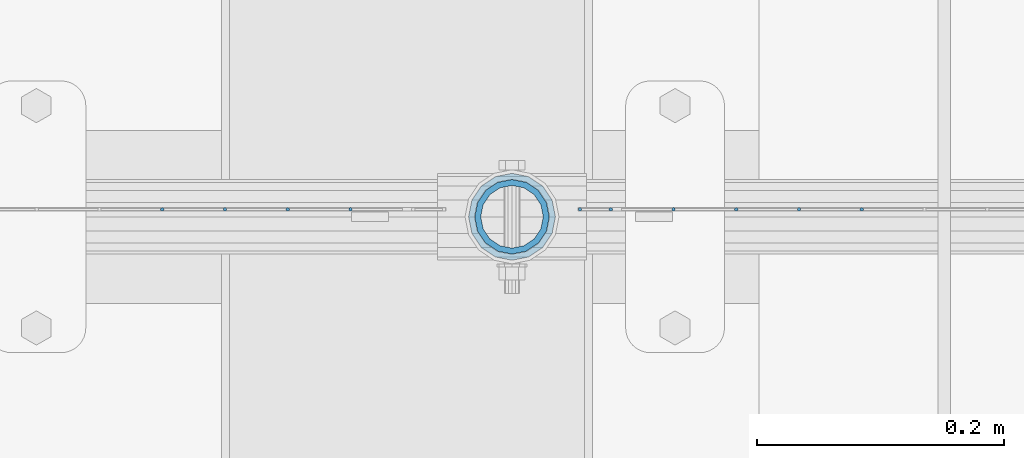
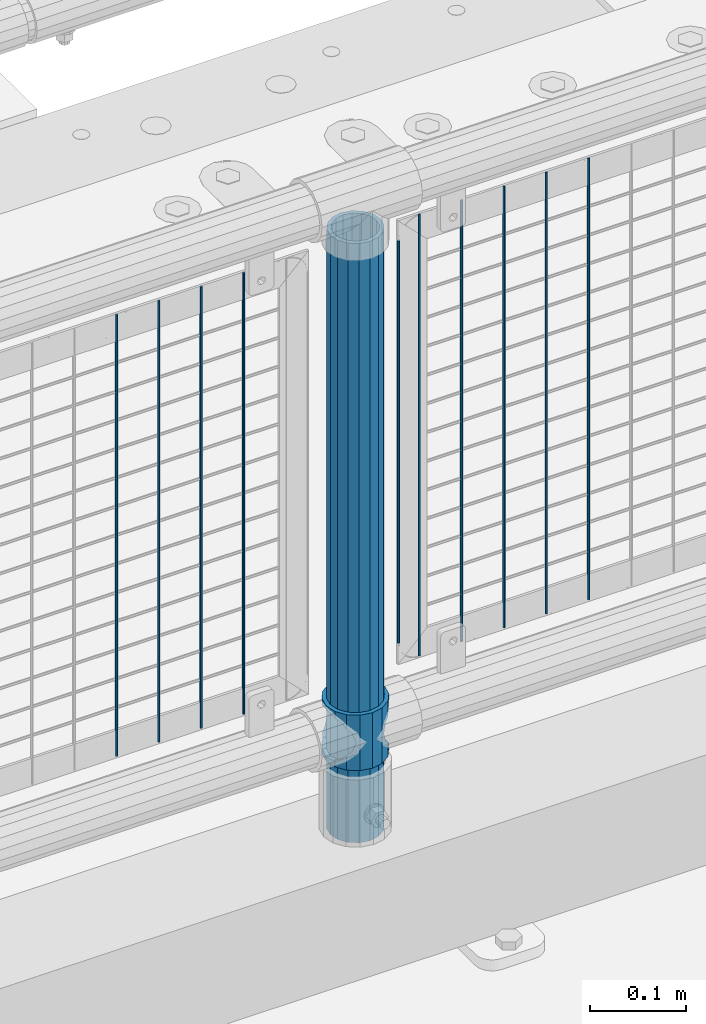
# One storey, part 91 of 242: 12 columns.
"""IFC2X3 building model written with IfcOpenShell, lengths in millimetres."""

from ifc_helpers import new_model, si_unit, frame, origin_with_axes, place, context, subcontext, project, spatial, faceted_brep, material, type_object, element, save


model = new_model("IFC2X3")

# Units and contexts
model_context = context("Model", 3, precision=1e-05, world=origin_with_axes())
body_context = subcontext(model_context, "Body", "Model", "MODEL_VIEW")
ifc_project = project(units=[si_unit("LENGTHUNIT", "METRE", prefix="MILLI"), si_unit("AREAUNIT", "SQUARE_METRE"), si_unit("VOLUMEUNIT", "CUBIC_METRE"), si_unit("MASSUNIT", "GRAM", prefix="KILO"), si_unit("TIMEUNIT", "SECOND"), si_unit("PLANEANGLEUNIT", "RADIAN"), si_unit("SOLIDANGLEUNIT", "STERADIAN"), si_unit("THERMODYNAMICTEMPERATUREUNIT", "DEGREE_CELSIUS"), si_unit("LUMINOUSINTENSITYUNIT", "LUMEN")], contexts=[model_context])

# Site, building, storey
site_placement = place(None, origin_with_axes())
site = spatial("IfcSite", under=ifc_project, at=site_placement, CompositionType="ELEMENT")
building_placement = place(site_placement, origin_with_axes())
building = spatial("IfcBuilding", under=site, at=building_placement, Name="Standard", CompositionType="ELEMENT")
storey_placement = place(building_placement, origin_with_axes())
storey = spatial("IfcBuildingStorey", under=building, at=storey_placement, Name="Undefined", CompositionType="ELEMENT", Elevation=0.0)

# Columns
ifc_material_1 = material()
column_type_1 = type_object("IfcColumnType", PredefinedType="NOTDEFINED")
column_1_placement = place(storey_placement, frame((-28765.0, -19335.5, 168.02), z_axis=(-1.0, 0.0, 0.0), x_axis=(0.0, 0.0, 1.0)))
element("IfcColumn", 1, at=column_1_placement, inside=storey, type_object=column_type_1, material=ifc_material_1, context=body_context, shape_type="Brep", body=[
    faceted_brep([(0.0, -25.3499999999985, 0.0), (0.0, -23.4203461491597, 9.70102501045403), (760.0, -23.4203461491597, 9.70102501045403), (760.0, -25.3499999999985, 0.0), (0.0, -17.9251569030785, 17.9251569030785), (760.0, -17.9251569030785, 17.9251569030785), (0.0, -9.70102501045403, 23.4203461491597), (760.0, -9.70102501045403, 23.4203461491597), (0.0, 0.0, 25.3499999999985), (760.0, 0.0, 25.3499999999985), (0.0, 9.70102501045403, 23.4203461491597), (760.0, 9.70102501045403, 23.4203461491597), (0.0, 17.9251569030785, 17.9251569030785), (760.0, 17.9251569030785, 17.9251569030785), (0.0, 23.4203461491597, 9.70102501045403), (760.0, 23.4203461491597, 9.70102501045403), (0.0, 25.3499999999985, 0.0), (760.0, 25.3499999999985, 0.0), (0.0, 23.4203461491597, -9.70102501045403), (760.0, 23.4203461491597, -9.70102501045403), (0.0, 17.9251569030785, -17.9251569030785), (760.0, 17.9251569030785, -17.9251569030785), (0.0, 9.70102501045403, -23.4203461491597), (760.0, 9.70102501045403, -23.4203461491597), (0.0, 0.0, -25.3499999999985), (760.0, 0.0, -25.3499999999985), (0.0, -9.70102501045403, -23.4203461491597), (760.0, -9.70102501045403, -23.4203461491597), (0.0, -17.9251569030785, -17.9251569030785), (760.0, -17.9251569030785, -17.9251569030785), (0.0, -23.4203461491597, -9.70102501045403), (760.0, -23.4203461491597, -9.70102501045403), (0.0, -30.1500000000015, 0.0), (0.0, -27.8549679052157, -11.5379054858058), (760.0, -27.8549679052157, -11.5379054858058), (760.0, -30.1500000000015, 0.0), (0.0, -21.3192694527752, -21.3192694527752), (760.0, -21.3192694527752, -21.3192694527752), (0.0, -11.5379054858058, -27.8549679052157), (760.0, -11.5379054858058, -27.8549679052157), (0.0, 0.0, -30.1500000000015), (760.0, 0.0, -30.1500000000015), (0.0, 11.5379054858058, -27.8549679052157), (760.0, 11.5379054858058, -27.8549679052157), (0.0, 21.3192694527752, -21.3192694527752), (760.0, 21.3192694527752, -21.3192694527752), (0.0, 27.8549679052157, -11.5379054858058), (760.0, 27.8549679052157, -11.5379054858058), (0.0, 30.1500000000015, 0.0), (760.0, 30.1500000000015, 0.0), (0.0, 27.8549679052157, 11.5379054858058), (760.0, 27.8549679052157, 11.5379054858058), (0.0, 21.3192694527752, 21.3192694527752), (760.0, 21.3192694527752, 21.3192694527752), (0.0, 11.5379054858058, 27.8549679052157), (760.0, 11.5379054858058, 27.8549679052157), (0.0, 0.0, 30.1500000000015), (760.0, 0.0, 30.1500000000015), (0.0, -11.5379054858058, 27.8549679052157), (760.0, -11.5379054858058, 27.8549679052157), (0.0, -21.3192694527752, 21.3192694527752), (760.0, -21.3192694527752, 21.3192694527752), (0.0, -27.8549679052157, 11.5379054858058), (760.0, -27.8549679052157, 11.5379054858058)], [[[0, 1, 2, 3]], [[1, 4, 5, 2]], [[4, 6, 7, 5]], [[6, 8, 9, 7]], [[8, 10, 11, 9]], [[10, 12, 13, 11]], [[12, 14, 15, 13]], [[14, 16, 17, 15]], [[16, 18, 19, 17]], [[18, 20, 21, 19]], [[20, 22, 23, 21]], [[22, 24, 25, 23]], [[24, 26, 27, 25]], [[26, 28, 29, 27]], [[28, 30, 31, 29]], [[30, 0, 3, 31]], [[32, 33, 34, 35]], [[33, 36, 37, 34]], [[36, 38, 39, 37]], [[38, 40, 41, 39]], [[40, 42, 43, 41]], [[42, 44, 45, 43]], [[44, 46, 47, 45]], [[46, 48, 49, 47]], [[48, 50, 51, 49]], [[50, 52, 53, 51]], [[52, 54, 55, 53]], [[54, 56, 57, 55]], [[56, 58, 59, 57]], [[58, 60, 61, 59]], [[60, 62, 63, 61]], [[62, 32, 35, 63]], [[37, 39, 41, 43, 45, 47, 49, 51, 53, 55, 57, 59, 61, 63, 35, 34], [5, 7, 9, 11, 13, 15, 17, 19, 21, 23, 25, 27, 29, 31, 3, 2]], [[62, 60, 58, 56, 54, 52, 50, 48, 46, 44, 42, 40, 38, 36, 33, 32], [30, 28, 26, 24, 22, 20, 18, 16, 14, 12, 10, 8, 6, 4, 1, 0]]]),
])
ifc_material_2 = material(Name="Misc_Undefined")
column_type_2 = type_object("IfcColumnType", PredefinedType="NOTDEFINED")
column_2_placement = place(storey_placement, frame((-28765.0, -19335.5, 263.02), z_axis=(-1.0, 0.0, 0.0), x_axis=(0.0, 0.0, 1.0)))
element("IfcColumn", 2, at=column_2_placement, inside=storey, type_object=column_type_2, material=ifc_material_2, context=body_context, shape_type="Brep", body=[
    faceted_brep([(63.1897438117172, 11.614442172282, -32.8397438117245), (63.1897438117172, 11.614442172282, -28.0397438117143), (56.6106908090114, 21.46069080901, -21.4606908090136), (56.6106908090114, 21.46069080901, -27.1226768591077), (61.9623795176744, 13.4513226476338, -32.4743655677739), (46.7644421722801, 28.0397438117179, -11.6144421722784), (46.7644421722801, 28.0397438117179, -20.0882031229849), (51.5310424080006, 24.8548033587067, -24.8548033587067), (35.1500000000015, 30.35, 0.0), (35.1499999999996, 30.3499999999985, -16.6306603983685), (23.5355578277192, 28.0397438117179, -11.6144421722784), (23.5355578277192, 28.0397438117179, -20.0882031229849), (18.7689575919987, 24.8548033587067, -24.8548033587067), (13.6893091909879, 21.46069080901, -21.4606908090136), (13.6893091909879, 21.46069080901, -27.1226768591077), (8.33762048232262, 13.4513226476338, -32.4743655677739), (7.11025618828211, 11.614442172282, -28.0397438117143), (7.11025618828211, 11.614442172282, -32.8397438117245), (4.79999999999961, 0.0, -30.3499999999985), (4.79999999999961, 0.0, -35.1500000000015), (7.11025618828211, -11.614442172282, -28.0397438117143), (7.11025618828211, -11.614442172282, -32.8397438117172), (13.6893091909879, -21.46069080901, -21.4606908090136), (13.6893091909879, -21.46069080901, -27.1226768591077), (8.33762048232484, -13.4513226476338, -32.4743655677739), (23.5355578277191, -28.0397438117179, -11.6144421722784), (23.5355578277191, -28.0397438117179, -20.0882031229921), (18.7689575919975, -24.8548033587067, -24.8548033587067), (35.1500000000015, -30.35, 0.0), (35.1499999999996, -30.3499999999985, -16.6306603983758), (46.7644421722801, -28.0397438117179, -11.6144421722784), (46.7644421722801, -28.0397438117179, -20.0882031229921), (51.5310424079973, -24.8548033587067, -24.8548033587067), (56.6106908090114, -21.46069080901, -21.4606908090136), (56.6106908090114, -21.46069080901, -27.1226768591077), (61.9623795176767, -13.4513226476338, -32.4743655677739), (63.1897438117172, -11.614442172282, -28.0397438117143), (63.1897438117172, -11.614442172282, -32.8397438117172), (65.4999999999997, 0.0, -30.3499999999985), (65.4999999999997, 0.0, -35.1500000000015), (0.0, -28.0397438117179, -11.6144421722784), (0.0, -30.3499999999985, 0.0), (0.0, -21.46069080901, -21.4606908090136), (0.0, -11.614442172282, -28.0397438117143), (0.0, 0.0, -30.3499999999985), (0.0, 11.614442172282, -28.0397438117143), (0.0, 21.46069080901, -21.4606908090136), (0.0, 28.0397438117179, -11.6144421722784), (0.0, 30.3499999999985, 0.0), (0.0, 28.0397438117179, 11.6144421722784), (23.5355578277192, 28.0397438117179, 11.614442172282), (0.0, 21.46069080901, 21.4606908090136), (13.6893091909879, 21.46069080901, 21.46069080901), (0.0, 11.614442172282, 28.0397438117143), (7.11025618828211, 11.614442172282, 28.0397438117179), (0.0, 0.0, 30.3499999999985), (4.79999999999961, 0.0, 30.3499999999985), (0.0, -11.614442172282, 28.0397438117143), (7.11025618828205, -11.614442172282, 28.0397438117179), (0.0, -21.46069080901, 21.4606908090136), (13.6893091909879, -21.46069080901, 21.46069080901), (0.0, -28.0397438117179, 11.6144421722784), (23.5355578277191, -28.0397438117179, 11.614442172282), (0.0, -32.4743655677703, 13.4513226476338), (0.0, -35.1500000000015, 0.0), (70.2999999999993, -35.1500000000015, 0.0), (70.2999999999993, -32.4743655677703, 13.4513226476338), (0.0, 13.4513226476338, -32.4743655677739), (0.0, 24.8548033587067, -24.8548033587067), (0.0, 0.0, -35.1500000000015), (0.0, -13.4513226476338, -32.4743655677739), (0.0, -24.8548033587067, -24.8548033587067), (0.0, -24.8548033587067, 24.8548033587067), (0.0, -13.4513226476338, 32.4743655677739), (0.0, 0.0, 35.1500000000015), (0.0, 13.4513226476338, 32.4743655677739), (0.0, 24.8548033587067, 24.8548033587067), (0.0, 32.4743655677703, 13.4513226476338), (0.0, 35.1500000000015, 0.0), (0.0, 32.4743655677703, -13.4513226476338), (0.0, -32.4743655677703, -13.4513226476338), (70.2999999999993, 32.4743655677703, 13.4513226476338), (70.2999999999993, 35.1500000000015, 0.0), (70.2999999999993, 32.4743655677703, -13.4513226476338), (70.2999999999993, 24.8548033587067, -24.8548033587067), (70.2999999999993, 13.4513226476338, -32.4743655677739), (70.2999999999993, 0.0, -35.1500000000015), (70.2999999999993, -13.4513226476338, -32.4743655677739), (70.2999999999993, -24.8548033587067, -24.8548033587067), (70.2999999999993, -32.4743655677703, -13.4513226476338), (70.2999999999993, 28.0397438117179, 11.6144421722784), (70.2999999999993, 21.46069080901, 21.4606908090136), (56.6106908090114, 21.46069080901, 21.46069080901), (46.7644421722801, 28.0397438117179, 11.614442172282), (70.2999999999993, 11.614442172282, 28.0397438117143), (63.1897438117172, 11.614442172282, 28.0397438117179), (70.2999999999993, 0.0, 30.3499999999985), (65.4999999999997, 0.0, 30.3499999999985), (70.2999999999993, -11.614442172282, 28.0397438117143), (63.1897438117172, -11.614442172282, 28.0397438117179), (70.2999999999993, -21.46069080901, 21.4606908090136), (56.6106908090114, -21.46069080901, 21.46069080901), (70.2999999999993, -28.0397438117179, 11.6144421722784), (46.7644421722801, -28.0397438117179, 11.614442172282), (70.2999999999993, -11.614442172282, -28.0397438117143), (70.2999999999993, 0.0, -30.3499999999985), (70.2999999999993, -21.46069080901, -21.4606908090136), (70.2999999999993, -28.0397438117179, -11.6144421722784), (70.2999999999993, -30.3499999999985, 0.0), (70.2999999999993, 24.8548033587067, 24.8548033587067), (70.2999999999993, 13.4513226476338, 32.4743655677739), (70.2999999999993, 0.0, 35.1500000000015), (70.2999999999993, -13.4513226476338, 32.4743655677739), (70.2999999999993, -24.8548033587067, 24.8548033587067), (70.2999999999993, 30.3499999999985, 0.0), (70.2999999999993, 28.0397438117179, -11.6144421722784), (70.2999999999993, 21.46069080901, -21.4606908090136), (70.2999999999993, 11.614442172282, -28.0397438117143), (61.9623795176744, 13.4513226476338, 32.4743655677703), (51.5310424080006, 24.8548033587067, 24.8548033587067), (56.6106908090114, 21.46069080901, 27.1226768591077), (65.4999999999997, 0.0, 35.1500000000015), (63.1897438117172, 11.614442172282, 32.8397438117136), (63.1897438117172, -11.614442172282, 32.8397438117172), (61.9623795176767, -13.4513226476338, 32.4743655677703), (56.6106908090114, -21.46069080901, 27.1226768591077), (51.5310424080038, -24.8548033587067, 24.8548033587067), (18.7689575919954, -24.8548033587067, 24.8548033587067), (46.7644421722801, -28.0397438117179, 20.0882031229885), (35.1499999999996, -30.3499999999985, 16.6306603983685), (23.5355578277191, -28.0397438117179, 20.0882031229885), (8.33762048232484, -13.4513226476338, 32.4743655677703), (13.6893091909879, -21.46069080901, 27.1226768591077), (4.79999999999961, 0.0, 35.1500000000015), (7.11025618828205, -11.614442172282, 32.8397438117172), (7.11025618828211, 11.614442172282, 32.8397438117136), (8.33762048232262, 13.4513226476338, 32.4743655677703), (13.6893091909879, 21.46069080901, 27.1226768591077), (18.768957592002, 24.8548033587067, 24.8548033587067), (23.5355578277192, 28.0397438117179, 20.0882031229812), (35.1499999999996, 30.3499999999985, 16.6306603983721), (46.7644421722801, 28.0397438117179, 20.0882031229812)], [[[0, 1, 2, 3, 4]], [[3, 2, 5, 6, 7]], [[6, 5, 8, 9]], [[9, 8, 10, 11]], [[12, 11, 10, 13, 14]], [[15, 14, 13, 16, 17]], [[17, 16, 18, 19]], [[19, 18, 20, 21]], [[21, 20, 22, 23, 24]], [[23, 22, 25, 26, 27]], [[26, 25, 28, 29]], [[29, 28, 30, 31]], [[32, 31, 30, 33, 34]], [[35, 34, 33, 36, 37]], [[37, 36, 38, 39]], [[39, 38, 1, 0]], [[40, 41, 28, 25]], [[42, 40, 25, 22]], [[43, 42, 22, 20]], [[44, 43, 20, 18]], [[45, 44, 18, 16]], [[46, 45, 16, 13]], [[47, 46, 13, 10]], [[48, 47, 10, 8]], [[49, 48, 8, 50]], [[51, 49, 50, 52]], [[53, 51, 52, 54]], [[55, 53, 54, 56]], [[57, 55, 56, 58]], [[59, 57, 58, 60]], [[61, 59, 60, 62]], [[41, 61, 62, 28]], [[63, 64, 65, 66]], [[67, 68, 12, 14, 15]], [[69, 67, 15, 17, 19]], [[24, 70, 69, 19, 21]], [[27, 71, 70, 24, 23]], [[63, 72, 73, 74, 75, 76, 77, 78, 79, 68, 67, 69, 70, 71, 80, 64], [40, 42, 43, 44, 45, 46, 47, 48, 49, 51, 53, 55, 57, 59, 61, 41]], [[78, 77, 81, 82]], [[79, 78, 82, 83]], [[68, 79, 83, 84, 7, 6, 9, 11, 12]], [[7, 84, 85, 4, 3]], [[4, 85, 86, 39, 0]], [[87, 88, 32, 34, 35]], [[86, 87, 35, 37, 39]], [[29, 31, 32, 88, 89, 80, 71, 27, 26]], [[64, 80, 89, 65]], [[90, 91, 92, 93]], [[91, 94, 95, 92]], [[94, 96, 97, 95]], [[96, 98, 99, 97]], [[98, 100, 101, 99]], [[100, 102, 103, 101]], [[104, 105, 38, 36]], [[106, 104, 36, 33]], [[107, 106, 33, 30]], [[108, 107, 30, 28]], [[102, 108, 28, 103]], [[88, 87, 86, 85, 84, 83, 82, 81, 109, 110, 111, 112, 113, 66, 65, 89], [100, 98, 96, 94, 91, 90, 114, 115, 116, 117, 105, 104, 106, 107, 108, 102]], [[118, 110, 109, 119, 120]], [[121, 111, 110, 118, 122]], [[112, 111, 121, 123, 124]], [[113, 112, 124, 125, 126]], [[127, 72, 63, 66, 113, 126, 128, 129, 130]], [[131, 73, 72, 127, 132]], [[133, 74, 73, 131, 134]], [[75, 74, 133, 135, 136]], [[76, 75, 136, 137, 138]], [[119, 109, 81, 77, 76, 138, 139, 140, 141]], [[92, 120, 119, 141, 93]], [[95, 122, 118, 120, 92]], [[97, 121, 122, 95]], [[99, 123, 121, 97]], [[101, 125, 124, 123, 99]], [[103, 128, 126, 125, 101]], [[28, 129, 128, 103]], [[62, 130, 129, 28]], [[60, 132, 127, 130, 62]], [[58, 134, 131, 132, 60]], [[56, 133, 134, 58]], [[54, 135, 133, 56]], [[52, 137, 136, 135, 54]], [[50, 139, 138, 137, 52]], [[8, 140, 139, 50]], [[93, 141, 140, 8]], [[114, 90, 93, 8]], [[115, 114, 8, 5]], [[116, 115, 5, 2]], [[117, 116, 2, 1]], [[105, 117, 1, 38]]]),
])
column_type_3 = type_object("IfcColumnType", Name="D3", PredefinedType="NOTDEFINED")
for number, where, z_axis, x_axis in (
    (3, (-28481.828, -19329.5, 353.02), (-1.0, 0.0, 0.0), (0.0, 0.0, 1.0)),
    (4, (-28532.621, -19329.5, 353.02), (-1.0, 0.0, 0.0), (0.0, 0.0, 1.0)),
    (5, (-28583.414, -19329.5, 353.02), (-1.0, 0.0, 0.0), (0.0, 0.0, 1.0)),
    (6, (-28634.207, -19329.5, 353.02), (-1.0, 0.0, 0.0), (0.0, 0.0, 1.0)),
):
    element("IfcColumn", number, at=place(storey_placement, frame(where, z_axis=z_axis, x_axis=x_axis)), inside=storey, type_object=column_type_3, material=ifc_material_2, ObjectType="D3", context=body_context, shape_type="Brep", body=[
        faceted_brep([(0.0, -1.50000000000364, 0.0), (-3.63797880709171e-12, -0.750000000003638, -1.29903810567669), (560.0, -0.75, -1.29903810567703), (560.0, -1.5, 0.0), (0.0, 0.749999999996362, -1.29903810567669), (560.0, 0.75, -1.29903810567703), (-3.63797880709171e-12, 1.49999999999636, 0.0), (560.0, 1.5, 0.0), (0.0, 0.749999999996362, 1.29903810567669), (560.0, 0.75, 1.29903810567703), (-3.63797880709171e-12, -0.750000000003638, 1.29903810567669), (560.0, -0.75, 1.29903810567703)], [[[0, 1, 2, 3]], [[1, 4, 5, 2]], [[4, 6, 7, 5]], [[6, 8, 9, 7]], [[8, 10, 11, 9]], [[10, 0, 3, 11]], [[5, 7, 9, 11, 3, 2]], [[10, 8, 6, 4, 1, 0]]]),
    ])
column_3_placement = place(storey_placement, frame((-28710.0, -19329.5, 378.02), z_axis=(-1.0, 0.0, 0.0), x_axis=(0.0, 0.0, 1.0)))
element("IfcColumn", 7, at=column_3_placement, inside=storey, type_object=column_type_3, material=ifc_material_2, ObjectType="D3", context=body_context, shape_type="Brep", body=[
    faceted_brep([(0.0, -1.50000000000364, 0.0), (-3.63797880709171e-12, -0.750000000003638, -1.29903810567669), (510.0, -0.75, -1.29903810567703), (510.0, -1.5, 0.0), (0.0, 0.749999999996362, -1.29903810567669), (510.0, 0.75, -1.29903810567703), (-3.63797880709171e-12, 1.49999999999636, 0.0), (510.0, 1.5, 0.0), (0.0, 0.749999999996362, 1.29903810567669), (510.0, 0.75, 1.29903810567703), (-3.63797880709171e-12, -0.750000000003638, 1.29903810567669), (510.0, -0.75, 1.29903810567703)], [[[0, 1, 2, 3]], [[1, 4, 5, 2]], [[4, 6, 7, 5]], [[6, 8, 9, 7]], [[8, 10, 11, 9]], [[10, 0, 3, 11]], [[5, 7, 9, 11, 3, 2]], [[10, 8, 6, 4, 1, 0]]]),
])
for number, where, z_axis, x_axis in (
    (8, (-28685.0, -19329.5, 353.02), (-1.0, 0.0, 0.0), (0.0, 0.0, 1.0)),
    (9, (-28895.796, -19329.5, 353.02), (-1.0, 0.0, 0.0), (0.0, 0.0, 1.0)),
    (10, (-28946.589, -19329.5, 353.02), (-1.0, 0.0, 0.0), (0.0, 0.0, 1.0)),
    (11, (-28997.382, -19329.5, 353.02), (-1.0, 0.0, 0.0), (0.0, 0.0, 1.0)),
    (12, (-29048.175, -19329.5, 353.02), (-1.0, 0.0, 0.0), (0.0, 0.0, 1.0)),
):
    element("IfcColumn", number, at=place(storey_placement, frame(where, z_axis=z_axis, x_axis=x_axis)), inside=storey, type_object=column_type_3, material=ifc_material_2, ObjectType="D3", context=body_context, shape_type="Brep", body=[
        faceted_brep([(0.0, -1.50000000000364, 0.0), (-3.63797880709171e-12, -0.750000000003638, -1.29903810567669), (560.0, -0.75, -1.29903810567703), (560.0, -1.5, 0.0), (0.0, 0.749999999996362, -1.29903810567669), (560.0, 0.75, -1.29903810567703), (-3.63797880709171e-12, 1.49999999999636, 0.0), (560.0, 1.5, 0.0), (0.0, 0.749999999996362, 1.29903810567669), (560.0, 0.75, 1.29903810567703), (-3.63797880709171e-12, -0.750000000003638, 1.29903810567669), (560.0, -0.75, 1.29903810567703)], [[[0, 1, 2, 3]], [[1, 4, 5, 2]], [[4, 6, 7, 5]], [[6, 8, 9, 7]], [[8, 10, 11, 9]], [[10, 0, 3, 11]], [[5, 7, 9, 11, 3, 2]], [[10, 8, 6, 4, 1, 0]]]),
    ])

save(model, "model.ifc")
